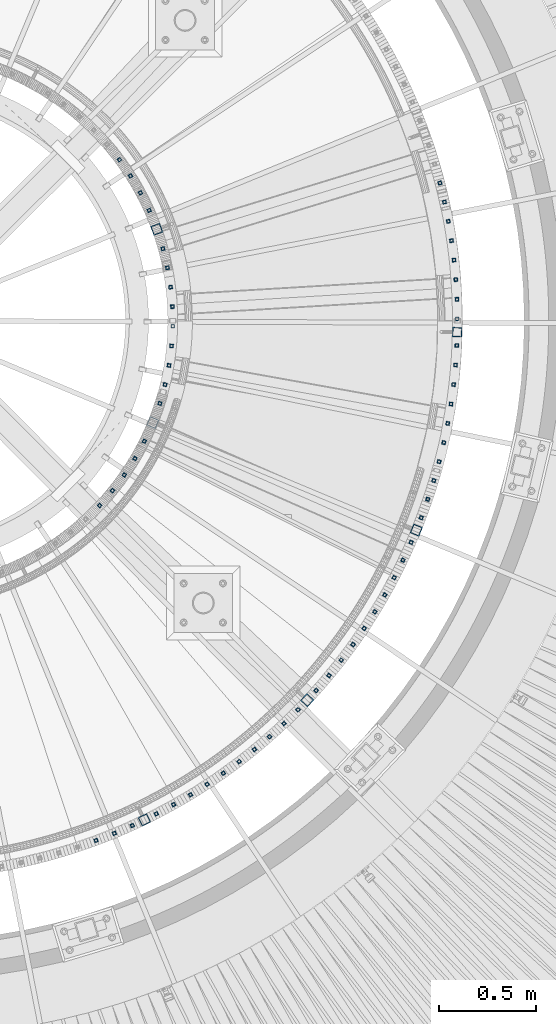
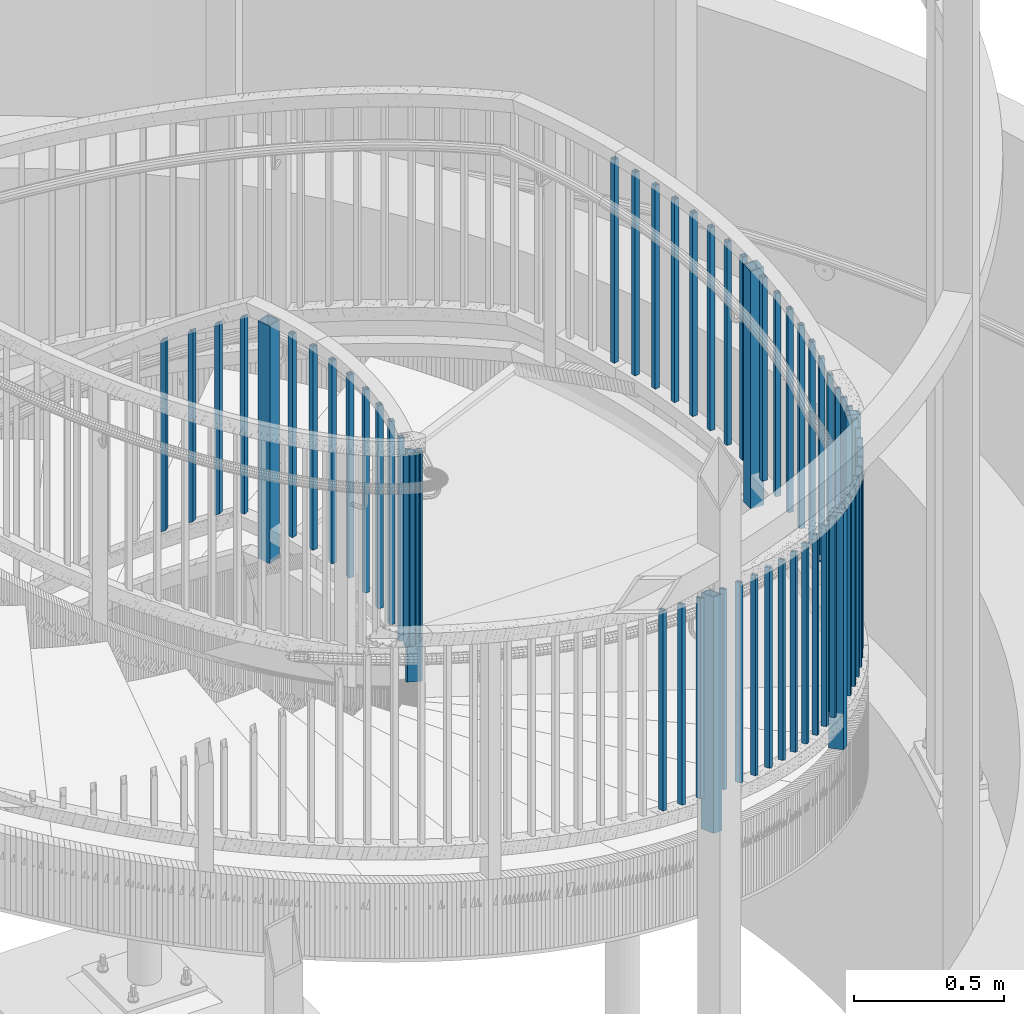
# One storey, part 266 of 975: 65 columns.
"""IFC2X3 building model written with IfcOpenShell, lengths in millimetres."""

from ifc_helpers import new_model, si_unit, frame, origin_with_axes, place, context, subcontext, project, spatial, faceted_brep, material, type_object, element, save


model = new_model("IFC2X3")

# Units and contexts
model_context = context("Model", 3, precision=1e-05, world=origin_with_axes())
body_context = subcontext(model_context, "Body", "Model", "MODEL_VIEW")
ifc_project = project(units=[si_unit("LENGTHUNIT", "METRE", prefix="MILLI"), si_unit("AREAUNIT", "SQUARE_METRE"), si_unit("VOLUMEUNIT", "CUBIC_METRE"), si_unit("MASSUNIT", "GRAM", prefix="KILO"), si_unit("TIMEUNIT", "SECOND"), si_unit("PLANEANGLEUNIT", "RADIAN"), si_unit("SOLIDANGLEUNIT", "STERADIAN"), si_unit("THERMODYNAMICTEMPERATUREUNIT", "DEGREE_CELSIUS"), si_unit("LUMINOUSINTENSITYUNIT", "LUMEN")], contexts=[model_context])

# Site, building, storey
site_placement = place(None, origin_with_axes())
site = spatial("IfcSite", under=ifc_project, at=site_placement, CompositionType="ELEMENT")
building_placement = place(site_placement, origin_with_axes())
building = spatial("IfcBuilding", under=site, at=building_placement, Name="Undefined", CompositionType="ELEMENT")
storey_placement = place(building_placement, origin_with_axes())
storey = spatial("IfcBuildingStorey", under=building, at=storey_placement, Name="Undefined", CompositionType="ELEMENT", Elevation=0.0)

# Columns
ifc_material = material()
column_type_1 = type_object("IfcColumnType", Name="HSS3/4X3/4X.120_TUBES", PredefinedType="NOTDEFINED")
column_1_placement = place(storey_placement, frame((36064.5939120754, 2975.51780285611, 2318.06072991597), z_axis=(0.949794781024638, -0.312873575008117, 0.0), x_axis=(0.0, 0.0, 1.0)))
element("IfcColumn", 1, at=column_1_placement, inside=storey, type_object=column_type_1, material=ifc_material, Name="PICKET", ObjectType="HSS3/4X3/4X.120_TUBES", context=body_context, shape_type="Brep", body=[
    faceted_brep([(81.3030822565961, 6.34999999999491, -6.34999999997672), (73.0243810963957, -6.34999999999854, -6.35000000000582), (849.31820965341, -6.34999999999854, -6.35000000000582), (857.556470281766, 6.34999999999491, -6.34999999997672), (73.0243810963952, -6.34999999999127, 6.34999999998399), (849.318209653409, -6.34999999999127, 6.34999999998399), (81.3030822565956, 6.35000000000218, 6.34999999999854), (857.556470281765, 6.35000000000218, 6.34999999999854), (83.3727575466464, 9.52499999999054, -9.52499999997235), (83.3727575466455, 9.52500000000509, 9.52500000000146), (859.616035438854, 9.52500000000509, 9.52500000000146), (859.616035438854, 9.52499999999054, -9.52499999997235), (70.9547058063449, -9.5249999999869, 9.52499999997235), (847.25864449632, -9.5249999999869, 9.52499999997235), (70.9547058063458, -9.52500000000146, -9.52499999999418), (847.258644496321, -9.52500000000146, -9.52499999999418)], [[[0, 1, 2, 3]], [[1, 4, 5, 2]], [[4, 6, 7, 5]], [[6, 0, 3, 7]], [[8, 9, 10, 11]], [[9, 12, 13, 10]], [[12, 14, 15, 13]], [[14, 8, 11, 15]], [[13, 15, 11, 10], [5, 7, 3, 2]], [[14, 12, 9, 8], [6, 4, 1, 0]]]),
])
for number, where, z_axis, x_axis, name in (
    (2, (37417.4267594475, 2384.13598263273, 2365.88275794022), (0.934865348987299, -0.355002505995178, 0.0), (0.0, 0.0, 1.0), "PICKET"),
    (3, (37451.8229924687, 2479.71763037491, 2333.53744594022), (0.946842586968158, -0.321697241989181, 0.0), (0.0, 0.0, 1.0), "PICKET"),
    (4, (37482.8152489475, 2576.45662080543, 2301.19213394022), (0.957633720255554, -0.287988989076854, 0.0), (0.0, 0.0, 1.0), "PICKET"),
    (5, (35734.5019327473, 713.238655086229, 3143.31977694143), (0.348608674988828, -0.937268366969959, 0.0), (0.0, 0.0, 1.0), "PICKET"),
    (6, (35829.0817873752, 750.311711588484, 3110.97446494143), (0.38155827111016, -0.924344787266865, 0.0), (0.0, 0.0, 1.0), "PICKET"),
    (7, (35922.2904650198, 790.708528685912, 3078.62915294143), (0.414029892105885, -0.910263285232789, 0.0), (0.0, 0.0, 1.0), "PICKET"),
    (8, (36046.148562522, 850.762180594981, 3035.20586745011), (0.457197304187946, -0.889365293365597, 0.0), (0.0, 0.0, 1.0), "PICKET"),
    (9, (36135.6665510303, 898.777615244103, 3002.86055545011), (0.488383698911202, -0.872628994841343, 0.0), (0.0, 0.0, 1.0), "PICKET"),
    (10, (36223.4293054007, 949.930828011724, 2970.51524345011), (0.518958296976197, -0.854799558960793, 0.0), (0.0, 0.0, 1.0), "PICKET"),
    (11, (36309.3268856819, 1004.15773953122, 2938.16993145011), (0.548882798941122, -0.835899319910335, 0.0), (0.0, 0.0, 1.0), "PICKET"),
    (12, (36393.251688417, 1061.39042002938, 2905.82461945011), (0.57811971765061, -0.815951954506869, 0.0), (0.0, 0.0, 1.0), "PICKET"),
    (13, (36475.098581437, 1121.55717442162, 2873.47930745011), (0.606632429084187, -0.794982450110327, 0.0), (0.0, 0.0, 1.0), "PICKET"),
    (14, (36554.7650355598, 1184.5826321241, 2841.13399545011), (0.634385216325158, -0.773017074396214, 0.0), (0.0, 0.0, 1.0), "PICKET"),
    (15, (36632.1512530282, 1250.38784147003, 2808.78868345011), (0.661343311181591, -0.750083345205964, 0.0), (0.0, 0.0, 1.0), "PICKET"),
    (16, (36707.1602925253, 1318.89036861203, 2776.44337145011), (0.687472945109045, -0.726209990115185, 0.0), (0.0, 0.0, 1.0), "PICKET"),
    (17, (36779.6981906131, 1390.0044007866, 2744.09805945011), (0.712741385856163, -0.701426914858445, 0.0), (0.0, 0.0, 1.0), "PICKET"),
    (18, (36873.8846786861, 1490.37338612447, 2700.64680894022), (0.745550470626476, -0.666449169666104, 0.0), (0.0, 0.0, 1.0), "PICKET"),
    (19, (36940.2497277328, 1567.28003405659, 2668.30149694022), (0.768667725015329, -0.639648285012755, 0.0), (0.0, 0.0, 1.0), "PICKET"),
    (20, (37003.8516454344, 1646.48703056447, 2635.95618494022), (0.7908220732947, -0.612046116228076, 0.0), (0.0, 0.0, 1.0), "PICKET"),
    (21, (37064.6107579957, 1727.89515345086, 2603.61087294022), (0.811985762603725, -0.583677240715147, 0.0), (0.0, 0.0, 1.0), "PICKET"),
    (22, (37122.4509527888, 1811.40242317881, 2571.26556094022), (0.832132281247357, -0.554577196164852, 0.0), (0.0, 0.0, 1.0), "PICKET"),
    (23, (37177.2997736992, 1896.90423062094, 2538.92024894022), (0.851236392637298, -0.524782434776394, 0.0), (0.0, 0.0, 1.0), "PICKET"),
    (24, (37229.0885118907, 1984.29346810271, 2506.57493694022), (0.869274164717492, -0.494330280839345, 0.0), (0.0, 0.0, 1.0), "PICKET"),
    (25, (37277.7522918776, 2073.46066357568, 2474.22962494022), (0.886223000920305, -0.463258882958341, 0.0), (0.0, 0.0, 1.0), "PICKET"),
    (26, (37323.2301527927, 2164.29411775258, 2441.88431294022), (0.902061670164132, -0.43160716307853, 0.0), (0.0, 0.0, 1.0), "PICKET"),
    (27, (37365.4651247536, 2256.68004403243, 2409.53900094022), (0.91677033194062, -0.399414769974129, 0.0), (0.0, 0.0, 1.0), "PICKET"),
):
    element("IfcColumn", number, at=place(storey_placement, frame(where, z_axis=z_axis, x_axis=x_axis)), inside=storey, type_object=column_type_1, material=ifc_material, Name=name, ObjectType="HSS3/4X3/4X.120_TUBES", context=body_context, shape_type="Brep", body=[
        faceted_brep([(48.9778304891588, 6.35000000000036, -6.34999999999854), (44.9444858438005, -6.35000000000582, -6.34999999999127), (858.946568247068, -6.35000000000582, -6.34999999999127), (863.063419332087, 6.35000000000036, -6.34999999999854), (44.9444858438051, -6.35000000000036, 6.35000000000582), (858.946568247072, -6.35000000000036, 6.35000000000582), (48.9778304891634, 6.350000000004, 6.34999999999854), (863.063419332091, 6.350000000004, 6.34999999999854), (49.9861666504976, 9.52499999999964, -9.52500000000146), (49.9861666505039, 9.52500000000691, 9.52499999999418), (864.092632103347, 9.52500000000691, 9.52499999999418), (864.09263210334, 9.52499999999964, -9.52500000000146), (43.9361496824667, -9.52500000000146, 9.52500000001601), (857.917355475819, -9.52500000000146, 9.52500000001601), (43.9361496824599, -9.52500000000691, -9.52499999997963), (857.917355475812, -9.52500000000691, -9.52499999997963)], [[[0, 1, 2, 3]], [[1, 4, 5, 2]], [[4, 6, 7, 5]], [[6, 0, 3, 7]], [[8, 9, 10, 11]], [[9, 12, 13, 10]], [[12, 14, 15, 13]], [[14, 8, 11, 15]], [[13, 15, 11, 10], [5, 7, 3, 2]], [[14, 12, 9, 8], [6, 4, 1, 0]]]),
    ])
for number, where, z_axis, x_axis, name in (
    (28, (35753.0345237352, 2447.80124868781, 2720.70328621885), (0.729207534132272, -0.684292607124125, 0.0), (0.0, 0.0, 1.0), "PICKET"),
    (29, (35819.7939649768, 2524.3384703423, 2654.02828621885), (0.777003152953844, -0.629496703962606, 0.0), (0.0, 0.0, 1.0), "PICKET"),
    (30, (35880.8154439247, 2605.5243582816, 2588.14703621885), (0.820690745194629, -0.571372646135501, 0.0), (0.0, 0.0, 1.0), "PICKET"),
    (31, (35935.7763392847, 2690.92968173818, 2523.05953621885), (0.860039337133624, -0.510227732079272, 0.0), (0.0, 0.0, 1.0), "PICKET"),
    (32, (35984.3860721407, 2780.10290173806, 2456.38453621885), (0.894840889994148, -0.44638523899708, 0.0), (0.0, 0.0, 1.0), "PICKET"),
):
    element("IfcColumn", number, at=place(storey_placement, frame(where, z_axis=z_axis, x_axis=x_axis)), inside=storey, type_object=column_type_1, material=ifc_material, Name=name, ObjectType="HSS3/4X3/4X.120_TUBES", context=body_context, shape_type="Brep", body=[
        faceted_brep([(81.3030822565961, 6.34999999999491, -6.34999999997672), (73.0243810963957, -6.34999999999854, -6.35000000000582), (849.31820965341, -6.34999999999854, -6.35000000000582), (857.556470281766, 6.34999999999491, -6.34999999997672), (73.0243810963952, -6.34999999999127, 6.34999999998399), (849.318209653409, -6.34999999999127, 6.34999999998399), (81.3030822565956, 6.35000000000218, 6.34999999999854), (857.556470281765, 6.35000000000218, 6.34999999999854), (83.3727575466464, 9.52499999999054, -9.52499999997235), (83.3727575466455, 9.52500000000509, 9.52500000000146), (859.616035438854, 9.52500000000509, 9.52500000000146), (859.616035438854, 9.52499999999054, -9.52499999997235), (70.9547058063449, -9.5249999999869, 9.52499999997235), (847.25864449632, -9.5249999999869, 9.52499999997235), (70.9547058063458, -9.52500000000146, -9.52499999999418), (847.258644496321, -9.52500000000146, -9.52499999999418)], [[[0, 1, 2, 3]], [[1, 4, 5, 2]], [[4, 6, 7, 5]], [[6, 0, 3, 7]], [[8, 9, 10, 11]], [[9, 12, 13, 10]], [[12, 14, 15, 13]], [[14, 8, 11, 15]], [[13, 15, 11, 10], [5, 7, 3, 2]], [[14, 12, 9, 8], [6, 4, 1, 0]]]),
    ])
for number, where, z_axis, x_axis, name in (
    (33, (37510.3633366045, 2674.22655896238, 2285.99999999872), (0.967224753663885, -0.253921790911761, 0.0), (0.0, 0.0, 1.0), "PICKET"),
    (34, (37534.4356666586, 2772.9153382479, 2285.99999999872), (0.975604690668889, -0.219534706925492, 0.0), (0.0, 0.0, 1.0), "PICKET"),
    (35, (37555.0005317003, 2872.39417296622, 2285.99999999872), (0.982762492663393, -0.184872612936678, 0.0), (0.0, 0.0, 1.0), "PICKET"),
    (36, (37572.0321702289, 2972.5384464926, 2285.99999999872), (0.988689192951112, -0.149978930992585, 0.0), (0.0, 0.0, 1.0), "PICKET"),
    (37, (37585.5092467984, 3073.22270861055, 2285.99999999872), (0.993377367431839, -0.114897371049948, 0.0), (0.0, 0.0, 1.0), "PICKET"),
    (38, (37595.4148787444, 3174.32083266262, 2285.99999999872), (0.996821143360912, -0.0796718780288463, 0.0), (0.0, 0.0, 1.0), "PICKET"),
    (39, (37601.7366573326, 3275.70617354867, 2285.99999999872), (0.999016206362438, -0.0443465830160885, 0.0), (0.0, 0.0, 1.0), "PICKET"),
):
    element("IfcColumn", number, at=place(storey_placement, frame(where, z_axis=z_axis, x_axis=x_axis)), inside=storey, type_object=column_type_1, material=ifc_material, Name=name, ObjectType="HSS3/4X3/4X.120_TUBES", context=body_context, shape_type="Brep", body=[
        faceted_brep([(38.1000007642197, 6.35000000000764, -6.35000000002765), (38.1000007642197, -6.35000000000036, -6.34999999999127), (863.600000001279, -6.35000000000036, -6.34999999999127), (863.600000001279, 6.35000000000764, -6.35000000002765), (38.1000007642197, -6.35000000000582, 6.35000000002765), (863.600000001279, -6.35000000000582, 6.35000000002765), (38.1000007642197, 6.35000000000036, 6.34999999999127), (863.600000001279, 6.35000000000036, 6.34999999999127), (38.1000007642197, 9.52500000001055, -9.52500000003783), (38.1000007642197, 9.52499999999964, 9.5249999999869), (863.600000001279, 9.52499999999964, 9.5249999999869), (863.600000001279, 9.52500000001055, -9.52500000003783), (38.1000007642197, -9.52500000001055, 9.52500000003783), (863.600000001279, -9.52500000001055, 9.52500000003783), (38.1000007642197, -9.52499999999964, -9.5249999999869), (863.600000001279, -9.52499999999964, -9.5249999999869)], [[[0, 1, 2, 3]], [[1, 4, 5, 2]], [[4, 6, 7, 5]], [[6, 0, 3, 7]], [[8, 9, 10, 11]], [[9, 12, 13, 10]], [[12, 14, 15, 13]], [[14, 8, 11, 15]], [[13, 15, 11, 10], [5, 7, 3, 2]], [[14, 12, 9, 8], [6, 4, 1, 0]]]),
    ])
column_2_placement = place(storey_placement, frame((36009.0003917963, 3975.10029214661, 2268.1326923435), z_axis=(0.912463211978783, 0.409158754990484, 0.0), x_axis=(0.0, 0.0, 1.0)))
element("IfcColumn", 40, at=column_2_placement, inside=storey, type_object=column_type_1, material=ifc_material, Name="PICKET", ObjectType="HSS3/4X3/4X.120_TUBES", context=body_context, shape_type="Brep", body=[
    faceted_brep([(55.9673084194355, 6.35000000000582, -6.34999999998399), (55.9673084194355, -6.35000000000036, -6.35000000000582), (849.31820965341, -6.34999999999854, -6.35000000000582), (857.556470281766, 6.34999999999491, -6.34999999997672), (55.9673084194355, -6.35000000000582, 6.34999999999127), (849.318209653409, -6.34999999999127, 6.34999999998399), (55.9673084194355, 6.35000000000036, 6.3500000000131), (857.556470281765, 6.35000000000218, 6.34999999999854), (55.9673084194355, 9.52500000001055, -9.52499999997963), (55.9673084194355, 9.52500000000327, 9.52500000001601), (859.616035438854, 9.52500000000509, 9.52500000000146), (859.616035438854, 9.52499999999054, -9.52499999997235), (55.9673084194355, -9.52500000000691, 9.5249999999869), (847.25864449632, -9.5249999999869, 9.52499999997235), (55.9673084194355, -9.52500000000327, -9.52500000000146), (847.258644496321, -9.52500000000146, -9.52499999999418)], [[[0, 1, 2, 3]], [[1, 4, 5, 2]], [[4, 6, 7, 5]], [[6, 0, 3, 7]], [[8, 9, 10, 11]], [[9, 12, 13, 10]], [[12, 14, 15, 13]], [[14, 8, 11, 15]], [[13, 15, 11, 10], [5, 7, 3, 2]], [[14, 12, 9, 8], [6, 4, 1, 0]]]),
])
column_3_placement = place(storey_placement, frame((36091.6393858432, 3073.24182939971, 2286.00000076294), z_axis=(0.971627954175823, -0.236514521042797, 0.0), x_axis=(0.0, 0.0, 1.0)))
element("IfcColumn", 41, at=column_3_placement, inside=storey, type_object=column_type_1, material=ifc_material, Name="PICKET", ObjectType="HSS3/4X3/4X.120_TUBES", context=body_context, shape_type="Brep", body=[
    faceted_brep([(38.1000007642197, 6.35000000000764, -6.35000000002765), (38.1000007642197, -6.35000000000036, -6.34999999999127), (863.600000001279, -6.35000000000036, -6.34999999999127), (863.600000001279, 6.35000000000764, -6.35000000002765), (38.1000007642197, -6.35000000000582, 6.35000000002765), (863.600000001279, -6.35000000000582, 6.35000000002765), (38.1000007642197, 6.35000000000036, 6.34999999999127), (863.600000001279, 6.35000000000036, 6.34999999999127), (38.1000007642197, 9.52500000001055, -9.52500000003783), (38.1000007642197, 9.52499999999964, 9.5249999999869), (863.600000001279, 9.52499999999964, 9.5249999999869), (863.600000001279, 9.52500000001055, -9.52500000003783), (38.1000007642197, -9.52500000001055, 9.52500000003783), (863.600000001279, -9.52500000001055, 9.52500000003783), (38.1000007642197, -9.52499999999964, -9.5249999999869), (863.600000001279, -9.52499999999964, -9.5249999999869)], [[[0, 1, 2, 3]], [[1, 4, 5, 2]], [[4, 6, 7, 5]], [[6, 0, 3, 7]], [[8, 9, 10, 11]], [[9, 12, 13, 10]], [[12, 14, 15, 13]], [[14, 8, 11, 15]], [[13, 15, 11, 10], [5, 7, 3, 2]], [[14, 12, 9, 8], [6, 4, 1, 0]]]),
])
column_4_placement = place(storey_placement, frame((35964.1038747739, 4066.1995349785, 2202.0530053435), z_axis=(0.880320091101838, 0.474380161054878, 0.0), x_axis=(0.0, 0.0, 1.0)))
element("IfcColumn", 42, at=column_4_placement, inside=storey, type_object=column_type_1, material=ifc_material, Name="PICKET", ObjectType="HSS3/4X3/4X.120_TUBES", context=body_context, shape_type="Brep", body=[
    faceted_brep([(81.3030822565961, 6.34999999999491, -6.34999999997672), (73.0243810963957, -6.34999999999854, -6.35000000000582), (849.31820965341, -6.34999999999854, -6.35000000000582), (857.556470281766, 6.34999999999491, -6.34999999997672), (73.0243810963952, -6.34999999999127, 6.34999999998399), (849.318209653409, -6.34999999999127, 6.34999999998399), (81.3030822565956, 6.35000000000218, 6.34999999999854), (857.556470281765, 6.35000000000218, 6.34999999999854), (83.3727575466464, 9.52499999999054, -9.52499999997235), (83.3727575466455, 9.52500000000509, 9.52500000000146), (859.616035438854, 9.52500000000509, 9.52500000000146), (859.616035438854, 9.52499999999054, -9.52499999997235), (70.9547058063449, -9.5249999999869, 9.52499999997235), (847.25864449632, -9.5249999999869, 9.52499999997235), (70.9547058063458, -9.52500000000146, -9.52499999999418), (847.258644496321, -9.52500000000146, -9.52499999999418)], [[[0, 1, 2, 3]], [[1, 4, 5, 2]], [[4, 6, 7, 5]], [[6, 0, 3, 7]], [[8, 9, 10, 11]], [[9, 12, 13, 10]], [[12, 14, 15, 13]], [[14, 8, 11, 15]], [[13, 15, 11, 10], [5, 7, 3, 2]], [[14, 12, 9, 8], [6, 4, 1, 0]]]),
])
column_5_placement = place(storey_placement, frame((36112.0568508554, 3172.73000162333, 2286.00000076294), z_axis=(0.986245487193393, -0.165287141032411, 0.0), x_axis=(0.0, 0.0, 1.0)))
element("IfcColumn", 43, at=column_5_placement, inside=storey, type_object=column_type_1, material=ifc_material, Name="PICKET", ObjectType="HSS3/4X3/4X.120_TUBES", context=body_context, shape_type="Brep", body=[
    faceted_brep([(38.1000007642197, 6.35000000000764, -6.35000000002765), (38.1000007642197, -6.35000000000036, -6.34999999999127), (863.600000001279, -6.35000000000036, -6.34999999999127), (863.600000001279, 6.35000000000764, -6.35000000002765), (38.1000007642197, -6.35000000000582, 6.35000000002765), (863.600000001279, -6.35000000000582, 6.35000000002765), (38.1000007642197, 6.35000000000036, 6.34999999999127), (863.600000001279, 6.35000000000036, 6.34999999999127), (38.1000007642197, 9.52500000001055, -9.52500000003783), (38.1000007642197, 9.52499999999964, 9.5249999999869), (863.600000001279, 9.52499999999964, 9.5249999999869), (863.600000001279, 9.52500000001055, -9.52500000003783), (38.1000007642197, -9.52500000001055, 9.52500000003783), (863.600000001279, -9.52500000001055, 9.52500000003783), (38.1000007642197, -9.52499999999964, -9.5249999999869), (863.600000001279, -9.52499999999964, -9.5249999999869)], [[[0, 1, 2, 3]], [[1, 4, 5, 2]], [[4, 6, 7, 5]], [[6, 0, 3, 7]], [[8, 9, 10, 11]], [[9, 12, 13, 10]], [[12, 14, 15, 13]], [[14, 8, 11, 15]], [[13, 15, 11, 10], [5, 7, 3, 2]], [[14, 12, 9, 8], [6, 4, 1, 0]]]),
])
column_6_placement = place(storey_placement, frame((35912.7064272531, 4153.79560608695, 2135.97331834351), z_axis=(0.84352270773921, 0.537093512833949, 0.0), x_axis=(0.0, 0.0, 1.0)))
element("IfcColumn", 44, at=column_6_placement, inside=storey, type_object=column_type_1, material=ifc_material, Name="PICKET", ObjectType="HSS3/4X3/4X.120_TUBES", context=body_context, shape_type="Brep", body=[
    faceted_brep([(81.3030822565961, 6.34999999999491, -6.34999999997672), (73.0243810963957, -6.34999999999854, -6.35000000000582), (849.31820965341, -6.34999999999854, -6.35000000000582), (857.556470281766, 6.34999999999491, -6.34999999997672), (73.0243810963952, -6.34999999999127, 6.34999999998399), (849.318209653409, -6.34999999999127, 6.34999999998399), (81.3030822565956, 6.35000000000218, 6.34999999999854), (857.556470281765, 6.35000000000218, 6.34999999999854), (83.3727575466464, 9.52499999999054, -9.52499999997235), (83.3727575466455, 9.52500000000509, 9.52500000000146), (859.616035438854, 9.52500000000509, 9.52500000000146), (859.616035438854, 9.52499999999054, -9.52499999997235), (70.9547058063449, -9.5249999999869, 9.52499999997235), (847.25864449632, -9.5249999999869, 9.52499999997235), (70.9547058063458, -9.52500000000146, -9.52499999999418), (847.258644496321, -9.52500000000146, -9.52499999999418)], [[[0, 1, 2, 3]], [[1, 4, 5, 2]], [[4, 6, 7, 5]], [[6, 0, 3, 7]], [[8, 9, 10, 11]], [[9, 12, 13, 10]], [[12, 14, 15, 13]], [[14, 8, 11, 15]], [[13, 15, 11, 10], [5, 7, 3, 2]], [[14, 12, 9, 8], [6, 4, 1, 0]]]),
])
column_7_placement = place(storey_placement, frame((36125.1911562025, 3273.43878630954, 2286.00000076294), z_axis=(0.995648728640298, -0.0931858849663339, 0.0), x_axis=(0.0, 0.0, 1.0)))
element("IfcColumn", 45, at=column_7_placement, inside=storey, type_object=column_type_1, material=ifc_material, Name="PICKET", ObjectType="HSS3/4X3/4X.120_TUBES", context=body_context, shape_type="Brep", body=[
    faceted_brep([(38.1000007642197, 6.35000000000764, -6.35000000002765), (38.1000007642197, -6.35000000000036, -6.34999999999127), (863.600000001279, -6.35000000000036, -6.34999999999127), (863.600000001279, 6.35000000000764, -6.35000000002765), (38.1000007642197, -6.35000000000582, 6.35000000002765), (863.600000001279, -6.35000000000582, 6.35000000002765), (38.1000007642197, 6.35000000000036, 6.34999999999127), (863.600000001279, 6.35000000000036, 6.34999999999127), (38.1000007642197, 9.52500000001055, -9.52500000003783), (38.1000007642197, 9.52499999999964, 9.5249999999869), (863.600000001279, 9.52499999999964, 9.5249999999869), (863.600000001279, 9.52500000001055, -9.52500000003783), (38.1000007642197, -9.52500000001055, 9.52500000003783), (863.600000001279, -9.52500000001055, 9.52500000003783), (38.1000007642197, -9.52499999999964, -9.5249999999869), (863.600000001279, -9.52499999999964, -9.5249999999869)], [[[0, 1, 2, 3]], [[1, 4, 5, 2]], [[4, 6, 7, 5]], [[6, 0, 3, 7]], [[8, 9, 10, 11]], [[9, 12, 13, 10]], [[12, 14, 15, 13]], [[14, 8, 11, 15]], [[13, 15, 11, 10], [5, 7, 3, 2]], [[14, 12, 9, 8], [6, 4, 1, 0]]]),
])
column_8_placement = place(storey_placement, frame((35855.0797881581, 4237.4253839888, 2069.89363134351), z_axis=(0.802265608927409, 0.596967245945984, 0.0), x_axis=(0.0, 0.0, 1.0)))
element("IfcColumn", 46, at=column_8_placement, inside=storey, type_object=column_type_1, material=ifc_material, Name="PICKET", ObjectType="HSS3/4X3/4X.120_TUBES", context=body_context, shape_type="Brep", body=[
    faceted_brep([(81.3030822565961, 6.34999999999491, -6.34999999997672), (73.0243810963957, -6.34999999999854, -6.35000000000582), (849.31820965341, -6.34999999999854, -6.35000000000582), (857.556470281766, 6.34999999999491, -6.34999999997672), (73.0243810963952, -6.34999999999127, 6.34999999998399), (849.318209653409, -6.34999999999127, 6.34999999998399), (81.3030822565956, 6.35000000000218, 6.34999999999854), (857.556470281765, 6.35000000000218, 6.34999999999854), (83.3727575466464, 9.52499999999054, -9.52499999997235), (83.3727575466455, 9.52500000000509, 9.52500000000146), (859.616035438854, 9.52500000000509, 9.52500000000146), (859.616035438854, 9.52499999999054, -9.52499999997235), (70.9547058063449, -9.5249999999869, 9.52499999997235), (847.25864449632, -9.5249999999869, 9.52499999997235), (70.9547058063458, -9.52500000000146, -9.52499999999418), (847.258644496321, -9.52500000000146, -9.52499999999418)], [[[0, 1, 2, 3]], [[1, 4, 5, 2]], [[4, 6, 7, 5]], [[6, 0, 3, 7]], [[8, 9, 10, 11]], [[9, 12, 13, 10]], [[12, 14, 15, 13]], [[14, 8, 11, 15]], [[13, 15, 11, 10], [5, 7, 3, 2]], [[14, 12, 9, 8], [6, 4, 1, 0]]]),
])
for number, where, z_axis, x_axis, name in (
    (47, (36130.9728606537, 3374.83573490052, 2286.00000076294), (0.999787963235336, -0.0205919540048471, 0.0), (0.0, 0.0, 1.0), "PICKET"),
    (48, (36129.3713962681, 3476.38476050759, 2286.00000076294), (0.998641306789424, 0.0521108469890118, 0.0), (0.0, 0.0, 1.0), "PICKET"),
    (49, (36120.3952300071, 3577.54897220906, 2286.00000076294), (0.992214821843802, 0.124538135980395, 0.0), (0.0, 0.0, 1.0), "PICKET"),
    (50, (36104.0918189699, 3677.79351359898, 2286.00000076294), (0.98054248500095, 0.19630699200019, 0.0), (0.0, 0.0, 1.0), "PICKET"),
    (51, (37604.5711562577, 3413.31792227737, 2285.99999999872), (0.999993518146461, 0.00360050900052738, 0.0), (0.0, 0.0, 1.0), "PICKET"),
    (52, (37602.4295978325, 3514.87758926486, 2285.99999999872), (0.999239760389025, 0.0389859110151782, 0.0), (0.0, 0.0, 1.0), "PICKET"),
    (53, (37596.6953987469, 3616.29785938846, 2285.99999999872), (0.997234260121404, 0.074322476009048, 0.0), (0.0, 0.0, 1.0), "PICKET"),
    (54, (37587.3757422026, 3717.45168399729, 2285.99999999872), (0.993979529588075, 0.109565937954594, 0.0), (0.0, 0.0, 1.0), "PICKET"),
    (55, (37574.4823028856, 3818.21234821541, 2285.99999999872), (0.989479646016883, 0.144672147002469, 0.0), (0.0, 0.0, 1.0), "PICKET"),
    (56, (37558.0312323409, 3918.45362967685, 2285.99999999872), (0.983740246360246, 0.179597126065768, 0.0), (0.0, 0.0, 1.0), "PICKET"),
    (57, (37538.0431387401, 4018.04995664377, 2285.99999999872), (0.976768520479758, 0.214297124105257, 0.0), (0.0, 0.0, 1.0), "PICKET"),
    (58, (37514.5430610651, 4116.8765653095, 2285.99999999872), (0.968573201563013, 0.248728673887782, 0.0), (0.0, 0.0, 1.0), "PICKET"),
    (59, (36080.547359487, 3776.58839057944, 2286.00000076294), (0.963686008271424, 0.267037970075212, 0.0), (0.0, 0.0, 1.0), "PICKET"),
):
    element("IfcColumn", number, at=place(storey_placement, frame(where, z_axis=z_axis, x_axis=x_axis)), inside=storey, type_object=column_type_1, material=ifc_material, Name=name, ObjectType="HSS3/4X3/4X.120_TUBES", context=body_context, shape_type="Brep", body=[
        faceted_brep([(38.1000007642197, 6.35000000000764, -6.35000000002765), (38.1000007642197, -6.35000000000036, -6.34999999999127), (863.600000001279, -6.35000000000036, -6.34999999999127), (863.600000001279, 6.35000000000764, -6.35000000002765), (38.1000007642197, -6.35000000000582, 6.35000000002765), (863.600000001279, -6.35000000000582, 6.35000000002765), (38.1000007642197, 6.35000000000036, 6.34999999999127), (863.600000001279, 6.35000000000036, 6.34999999999127), (38.1000007642197, 9.52500000001055, -9.52500000003783), (38.1000007642197, 9.52499999999964, 9.5249999999869), (863.600000001279, 9.52499999999964, 9.5249999999869), (863.600000001279, 9.52500000001055, -9.52500000003783), (38.1000007642197, -9.52500000001055, 9.52500000003783), (863.600000001279, -9.52500000001055, 9.52500000003783), (38.1000007642197, -9.52499999999964, -9.5249999999869), (863.600000001279, -9.52499999999964, -9.5249999999869)], [[[0, 1, 2, 3]], [[1, 4, 5, 2]], [[4, 6, 7, 5]], [[6, 0, 3, 7]], [[8, 9, 10, 11]], [[9, 12, 13, 10]], [[12, 14, 15, 13]], [[14, 8, 11, 15]], [[13, 15, 11, 10], [5, 7, 3, 2]], [[14, 12, 9, 8], [6, 4, 1, 0]]]),
    ])
column_type_2 = type_object("IfcColumnType", Name="HSS2X2X.188_TUBES", PredefinedType="NOTDEFINED")
for number, where, z_axis, x_axis, name in (
    (60, (35984.6070941398, 819.943619358641, 2903.18314487521), (0.435547032080205, -0.900165975165761, 0.0), (0.0, 0.0, 1.0), "HANDRAIL"),
    (61, (36827.4751534994, 1439.54729019194, 2569.01440487521), (0.729208818959546, -0.684291237962042, 0.0), (0.0, 0.0, 1.0), "HANDRAIL"),
    (62, (37392.314178944, 2320.05404792199, 2234.25035387521), (0.926003128233091, -0.37751583609503, 0.0), (0.0, 0.0, 1.0), "HANDRAIL"),
):
    element("IfcColumn", number, at=place(storey_placement, frame(where, z_axis=z_axis, x_axis=x_axis)), inside=storey, type_object=column_type_2, material=ifc_material, Name=name, ObjectType="HSS2X2X.188_TUBES", context=body_context, shape_type="Brep", body=[
        faceted_brep([(59.7770034089217, 20.6374999999425, -20.6375000000444), (46.6339334019876, -20.6375000000517, -20.6375000000335), (1006.79125658838, -20.6375000000517, -20.6375000000335), (1019.96851403156, 20.6374999999425, -20.6375000000444), (46.6339334020035, -20.6374999999389, 20.637500000048), (1006.7912565884, -20.6374999999389, 20.637500000048), (59.7770034089381, 20.6375000000517, 20.6375000000335), (1019.96851403158, 20.6375000000517, 20.6375000000335), (61.2935114866432, 25.3999999999287, -25.4000000000524), (61.2935114866632, 25.4000000000633, 25.4000000000415), (1021.48896681348, 25.4000000000633, 25.4000000000415), (1021.48896681346, 25.3999999999287, -25.4000000000524), (45.1174253242825, -25.3999999999251, 25.400000000056), (1005.27080380649, -25.3999999999251, 25.400000000056), (45.1174253242625, -25.4000000000597, -25.4000000000415), (1005.27080380647, -25.4000000000597, -25.4000000000415)], [[[0, 1, 2, 3]], [[1, 4, 5, 2]], [[4, 6, 7, 5]], [[6, 0, 3, 7]], [[8, 9, 10, 11]], [[9, 12, 13, 10]], [[12, 14, 15, 13]], [[14, 8, 11, 15]], [[13, 15, 11, 10], [5, 7, 3, 2]], [[14, 12, 9, 8], [6, 4, 1, 0]]]),
    ])
column_9_placement = place(storey_placement, frame((36028.1263696798, 2876.2103758497, 2235.34548738255), z_axis=(0.926003128233091, -0.37751583609503, 0.0), x_axis=(0.0, 0.0, 1.0)))
element("IfcColumn", 63, at=column_9_placement, inside=storey, type_object=column_type_2, material=ifc_material, Name="HANDRAIL", ObjectType="HSS2X2X.188_TUBES", context=body_context, shape_type="Brep", body=[
    faceted_brep([(73.8216023003633, 20.6375000000298, -20.6375000000116), (46.7511421721683, -20.6375000000044, -20.6374999999971), (991.653317693376, -20.6375000000044, -20.6374999999971), (1018.78995571227, 20.6375000000298, -20.6375000000116), (46.7511421721192, -20.6375000000262, 20.6375000000116), (991.653317693327, -20.6375000000262, 20.6375000000116), (73.8216023003142, 20.6375000000044, 20.6374999999953), (1018.78995571223, 20.6375000000044, 20.6374999999953), (76.9451169305453, 25.4000000000306, -25.4000000000124), (76.9451169304848, 25.4000000000051, 25.3999999999942), (1021.92110625286, 25.4000000000051, 25.3999999999942), (1021.92110625292, 25.4000000000306, -25.4000000000124), (43.6276275419368, -25.4000000000306, 25.4000000000124), (988.522167152679, -25.4000000000306, 25.4000000000124), (43.6276275419978, -25.4000000000015, -25.399999999996), (988.52216715274, -25.4000000000015, -25.399999999996)], [[[0, 1, 2, 3]], [[1, 4, 5, 2]], [[4, 6, 7, 5]], [[6, 0, 3, 7]], [[8, 9, 10, 11]], [[9, 12, 13, 10]], [[12, 14, 15, 13]], [[14, 8, 11, 15]], [[13, 15, 11, 10], [5, 7, 3, 2]], [[14, 12, 9, 8], [6, 4, 1, 0]]]),
])
for number, where, z_axis, x_axis, name in (
    (64, (37604.0913245223, 3344.49272273231, 2133.6), (0.999787932854836, -0.02059342899701, 0.0), (0.0, 0.0, 1.0), "HANDRAIL"),
    (65, (36048.7451828878, 3877.27562662298, 2133.6), (0.940762469801482, 0.339066328928449, 0.0), (0.0, 0.0, 1.0), "HANDRAIL"),
):
    element("IfcColumn", number, at=place(storey_placement, frame(where, z_axis=z_axis, x_axis=x_axis)), inside=storey, type_object=column_type_2, material=ifc_material, Name=name, ObjectType="HSS2X2X.188_TUBES", context=body_context, shape_type="Brep", body=[
        faceted_brep([(50.7999992370605, 20.6375000000016, -20.637500000099), (50.7999992370605, -20.6374999999998, -20.6375000000262), (1016.0, -20.6374999999935, -20.6374999999898), (1016.0, 20.6374999999716, -20.6375000000371), (50.7999992370605, -20.6375000000025, 20.6375000001208), (1016.0, -20.6374999999716, 20.6375000000226), (50.7999992370605, 20.637499999998, 20.6375000000407), (1016.0, 20.6374999999898, 20.6374999999789), (50.7999999999411, 25.3999999999996, -25.4000000000487), (50.8000000000102, 25.3999999999996, 25.4000000000015), (1016.00000000002, 25.4000000000087, 25.3999999999724), (1016.0, 25.3999999999651, -25.4000000000415), (50.7999992370605, -25.4000000000024, 25.400000000147), (1016.00000000003, -25.4000000000087, 25.4000000000124), (50.7999999999411, -25.3999999999996, -25.4000000000487), (1016.0, -25.3999999999869, -25.3999999999833)], [[[0, 1, 2, 3]], [[1, 4, 5, 2]], [[4, 6, 7, 5]], [[6, 0, 3, 7]], [[8, 9, 10, 11]], [[9, 12, 13, 10]], [[12, 14, 15, 13]], [[14, 8, 11, 15]], [[13, 15, 11, 10], [5, 7, 3, 2]], [[14, 12, 9, 8], [6, 4, 1, 0]]]),
    ])

save(model, "model.ifc")
